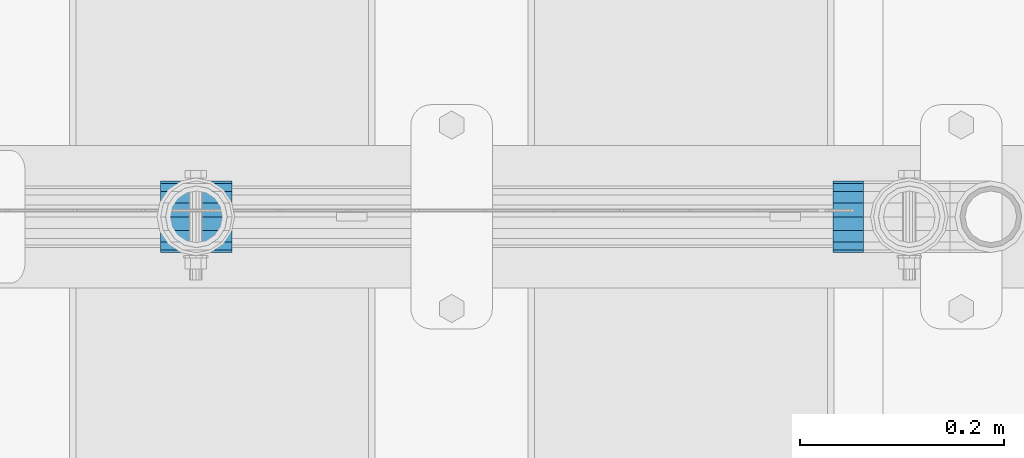
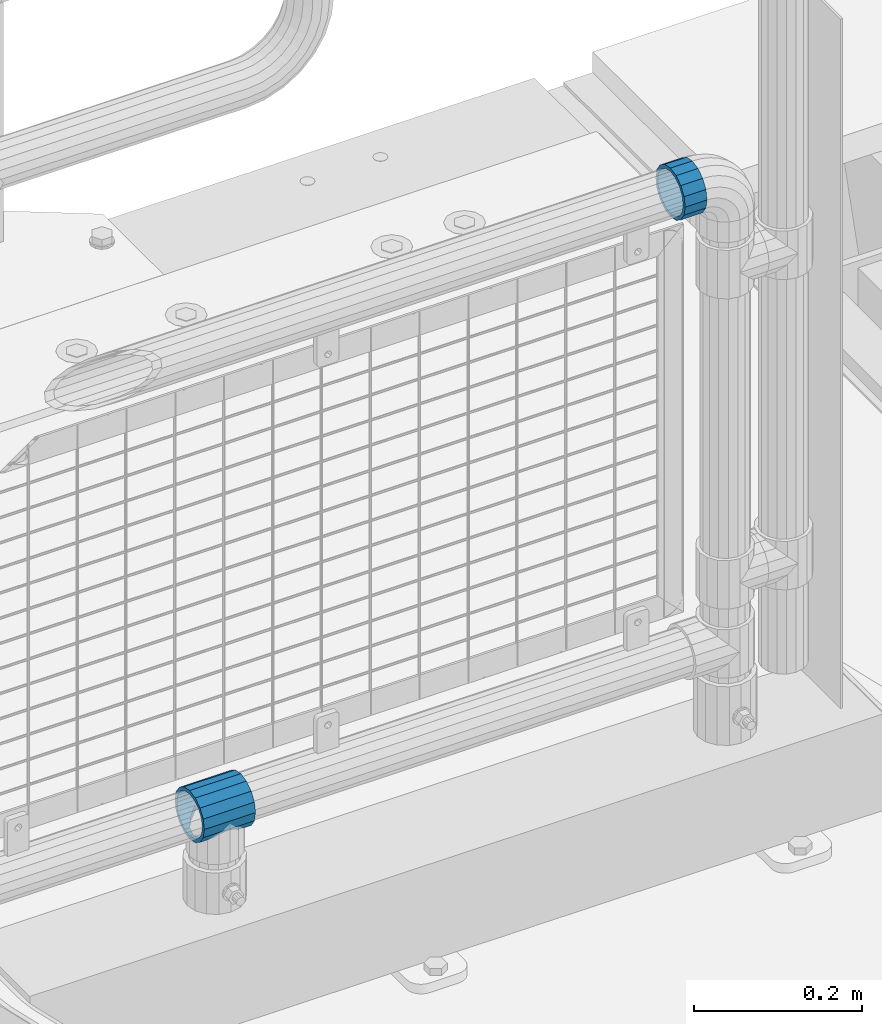
# One storey, part 189 of 270: 2 beams.
"""IFC2X3 building model written with IfcOpenShell, lengths in millimetres."""

from ifc_helpers import new_model, si_unit, frame, origin_with_axes, place, context, subcontext, project, spatial, faceted_brep, material, type_object, element, save


model = new_model("IFC2X3")

# Units and contexts
model_context = context("Model", 3, precision=1e-05, world=origin_with_axes())
body_context = subcontext(model_context, "Body", "Model", "MODEL_VIEW")
ifc_project = project(units=[si_unit("LENGTHUNIT", "METRE", prefix="MILLI"), si_unit("AREAUNIT", "SQUARE_METRE"), si_unit("VOLUMEUNIT", "CUBIC_METRE"), si_unit("MASSUNIT", "GRAM", prefix="KILO"), si_unit("TIMEUNIT", "SECOND"), si_unit("PLANEANGLEUNIT", "RADIAN"), si_unit("SOLIDANGLEUNIT", "STERADIAN"), si_unit("THERMODYNAMICTEMPERATUREUNIT", "DEGREE_CELSIUS"), si_unit("LUMINOUSINTENSITYUNIT", "LUMEN")], contexts=[model_context])

# Site, building, storey
site_placement = place(None, origin_with_axes())
site = spatial("IfcSite", under=ifc_project, at=site_placement, CompositionType="ELEMENT")
building_placement = place(site_placement, origin_with_axes())
building = spatial("IfcBuilding", under=site, at=building_placement, Name="Standard", CompositionType="ELEMENT")
storey_placement = place(building_placement, origin_with_axes())
storey = spatial("IfcBuildingStorey", under=building, at=storey_placement, Name="Undefined", CompositionType="ELEMENT", Elevation=0.0)

# Beams
ifc_material = material(Name="Misc_Undefined")
beam_type = type_object("IfcBeamType", PredefinedType="NOTDEFINED")
beam_1_placement = place(storey_placement, frame((19059.46, -16335.5, 298.169999999999), z_axis=(0.0, 0.0, 1.0), x_axis=(1.0, 0.0, 0.0)))
element("IfcBeam", 1, at=beam_1_placement, inside=storey, type_object=beam_type, material=ifc_material, context=body_context, shape_type="Brep", body=[
    faceted_brep([(61.9623795176767, -13.4513226476338, -32.4743655677703), (56.6106908090125, -21.4606908090118, -27.1226768591041), (56.6106908090125, -21.4606908090118, -21.46069080901), (63.1897438117183, -11.6144421722802, -28.0397438117179), (63.1897438117183, -11.6144421722802, -32.8397438117172), (51.5310424080071, -24.8548033587067, -24.8548033587067), (46.7644421722812, -28.0397438117179, -20.0882031229885), (46.7644421722812, -28.0397438117179, -11.614442172282), (35.1500000000008, -30.3500000000004, -16.6306603983721), (35.1500000000015, -30.35, 0.0), (23.5355578277203, -28.0397438117179, -20.0882031229885), (23.5355578277203, -28.0397438117179, -11.614442172282), (13.689309190989, -21.4606908090118, -27.1226768591041), (13.689309190989, -21.4606908090118, -21.46069080901), (18.7689575919954, -24.8548033587067, -24.8548033587067), (7.11025618828319, -11.6144421722802, -32.8397438117172), (7.11025618828319, -11.6144421722802, -28.0397438117179), (8.33762048232484, -13.4513226476338, -32.4743655677703), (4.80000000000075, 0.0, -35.1500000000015), (4.80000000000075, 0.0, -30.3499999999985), (7.11025618828324, 11.6144421722802, -32.8397438117208), (7.11025618828324, 11.6144421722802, -28.0397438117179), (8.33762048232484, 13.4513226476338, -32.4743655677703), (13.689309190989, 21.4606908090118, -27.1226768591005), (13.689309190989, 21.4606908090118, -21.46069080901), (18.7689575919954, 24.8548033587067, -24.8548033587067), (23.5355578277203, 28.0397438117179, -20.0882031229812), (23.5355578277203, 28.0397438117179, -11.614442172282), (35.1500000000008, 30.3500000000004, -16.6306603983612), (35.1500000000015, 30.35, 0.0), (46.7644421722812, 28.0397438117179, -20.0882031229812), (46.7644421722812, 28.0397438117179, -11.614442172282), (56.6106908090125, 21.4606908090118, -27.1226768591005), (56.6106908090125, 21.4606908090118, -21.46069080901), (51.5310424080071, 24.8548033587067, -24.8548033587067), (63.1897438117183, 11.6144421722802, -32.8397438117208), (63.1897438117183, 11.6144421722802, -28.0397438117179), (61.9623795176767, 13.4513226476338, -32.4743655677703), (65.5000000000008, 0.0, -35.1500000000015), (65.5000000000008, 0.0, -30.3499999999985), (0.0, -21.4606908090118, -21.46069080901), (0.0, -28.0397438117179, -11.614442172282), (0.0, -11.6144421722802, -28.0397438117179), (0.0, 0.0, -30.3499999999985), (0.0, 11.6144421722802, -28.0397438117179), (0.0, 21.4606908090118, -21.46069080901), (0.0, 28.0397438117179, -11.614442172282), (0.0, 30.3500000000004, 0.0), (0.0, 32.4743655677721, -13.4513226476338), (0.0, 35.1499999999996, 0.0), (70.2999999999993, 35.1499999999996, 0.0), (70.2999999999993, 32.4743655677721, -13.4513226476338), (0.0, 32.4743655677721, 13.4513226476338), (70.2999999999993, 32.4743655677721, 13.4513226476338), (0.0, 24.8548033587067, 24.8548033587067), (70.2999999999993, 24.8548033587067, 24.8548033587067), (0.0, 13.4513226476338, 32.4743655677703), (70.2999999999993, 13.4513226476338, 32.4743655677703), (0.0, 0.0, 35.1499999999996), (70.2999999999993, 0.0, 35.1500000000015), (0.0, -13.4513226476338, 32.4743655677703), (70.2999999999993, -13.4513226476338, 32.4743655677703), (0.0, -24.8548033587067, 24.8548033587067), (70.2999999999993, -24.8548033587067, 24.8548033587067), (0.0, -32.4743655677721, 13.4513226476338), (70.2999999999993, -32.4743655677721, 13.4513226476338), (0.0, -35.1499999999996, 0.0), (70.2999999999993, -35.1499999999996, 0.0), (0.0, -32.4743655677721, -13.4513226476338), (70.2999999999993, -32.4743655677721, -13.4513226476338), (0.0, 24.8548033587067, -24.8548033587067), (0.0, 13.4513226476338, -32.4743655677703), (0.0, 0.0, -35.1499999999996), (0.0, -13.4513226476338, -32.4743655677703), (0.0, -24.8548033587067, -24.8548033587067), (0.0, 28.0397438117179, 11.614442172282), (0.0, 21.4606908090118, 21.46069080901), (0.0, 11.6144421722802, 28.0397438117179), (0.0, 0.0, 30.3499999999985), (0.0, -11.6144421722802, 28.0397438117179), (0.0, -21.4606908090118, 21.46069080901), (0.0, -28.0397438117179, 11.614442172282), (0.0, -30.3500000000004, 0.0), (70.2999999999993, -30.3500000000004, 0.0), (70.2999999999993, -28.0397438117179, -11.614442172282), (70.2999999999993, -21.4606908090118, -21.46069080901), (70.2999999999993, -11.6144421722802, -28.0397438117179), (70.2999999999993, 0.0, -30.3499999999985), (70.2999999999993, 21.4606908090118, -21.46069080901), (70.2999999999993, 28.0397438117179, -11.614442172282), (70.2999999999993, 11.6144421722802, -28.0397438117179), (70.2999999999993, 30.3500000000004, 0.0), (70.2999999999993, 28.0397438117179, 11.614442172282), (70.2999999999993, 21.4606908090118, 21.46069080901), (70.2999999999993, 11.6144421722802, 28.0397438117179), (70.2999999999993, 0.0, 30.3499999999985), (70.2999999999993, -11.6144421722802, 28.0397438117179), (70.2999999999993, -21.4606908090118, 21.46069080901), (70.2999999999993, -28.0397438117179, 11.614442172282), (70.2999999999993, -24.8548033587067, -24.8548033587067), (70.2999999999993, -13.4513226476338, -32.4743655677703), (70.2999999999993, 0.0, -35.1500000000015), (70.2999999999993, 13.4513226476338, -32.4743655677703), (70.2999999999993, 24.8548033587067, -24.8548033587067)], [[[0, 1, 2, 3, 4]], [[5, 6, 7, 2, 1]], [[8, 9, 7, 6]], [[10, 11, 9, 8]], [[12, 13, 11, 10, 14]], [[15, 16, 13, 12, 17]], [[18, 19, 16, 15]], [[20, 21, 19, 18]], [[22, 23, 24, 21, 20]], [[25, 26, 27, 24, 23]], [[28, 29, 27, 26]], [[30, 31, 29, 28]], [[32, 33, 31, 30, 34]], [[35, 36, 33, 32, 37]], [[38, 39, 36, 35]], [[4, 3, 39, 38]], [[40, 41, 11, 13]], [[42, 40, 13, 16]], [[43, 42, 16, 19]], [[44, 43, 19, 21]], [[45, 44, 21, 24]], [[46, 45, 24, 27]], [[47, 46, 27, 29]], [[48, 49, 50, 51]], [[49, 52, 53, 50]], [[52, 54, 55, 53]], [[54, 56, 57, 55]], [[56, 58, 59, 57]], [[58, 60, 61, 59]], [[60, 62, 63, 61]], [[62, 64, 65, 63]], [[64, 66, 67, 65]], [[66, 68, 69, 67]], [[64, 62, 60, 58, 56, 54, 52, 49, 48, 70, 71, 72, 73, 74, 68, 66], [41, 40, 42, 43, 44, 45, 46, 47, 75, 76, 77, 78, 79, 80, 81, 82]], [[41, 82, 9, 11]], [[83, 84, 7, 9]], [[84, 85, 2, 7]], [[85, 86, 3, 2]], [[86, 87, 39, 3]], [[88, 89, 31, 33]], [[90, 88, 33, 36]], [[87, 90, 36, 39]], [[89, 91, 29, 31]], [[75, 47, 29, 91, 92]], [[76, 75, 92, 93]], [[77, 76, 93, 94]], [[78, 77, 94, 95]], [[79, 78, 95, 96]], [[80, 79, 96, 97]], [[81, 80, 97, 98]], [[9, 82, 81, 98, 83]], [[99, 100, 101, 102, 103, 51, 50, 53, 55, 57, 59, 61, 63, 65, 67, 69], [97, 96, 95, 94, 93, 92, 91, 89, 88, 90, 87, 86, 85, 84, 83, 98]], [[37, 102, 101, 38, 35]], [[34, 103, 102, 37, 32]], [[70, 48, 51, 103, 34, 30, 28, 26, 25]], [[71, 70, 25, 23, 22]], [[72, 71, 22, 20, 18]], [[17, 73, 72, 18, 15]], [[14, 74, 73, 17, 12]], [[8, 6, 5, 99, 69, 68, 74, 14, 10]], [[100, 99, 5, 1, 0]], [[101, 100, 0, 4, 38]]]),
])
beam_2_placement = place(storey_placement, frame((19749.0, -16335.5, 969.85), z_axis=(0.0, 0.0, 1.0), x_axis=(-1.0, 0.0, 0.0)))
element("IfcBeam", 2, at=beam_2_placement, inside=storey, type_object=beam_type, material=ifc_material, context=body_context, shape_type="Brep", body=[
    faceted_brep([(0.0, -30.3500000000004, 0.0), (0.0, -28.0397438117179, 11.614442172282), (30.0, -28.0397438117179, 11.6144421722805), (30.0, -30.3500000000004, 0.0), (0.0, -21.4606908090118, 21.46069080901), (30.0, -21.4606908090118, 21.4606908090117), (0.0, -11.6144421722802, 28.0397438117179), (30.0, -11.6144421722802, 28.0397438117176), (0.0, 0.0, 30.3499999999985), (30.0, 0.0, 30.35), (0.0, 11.6144421722802, 28.0397438117179), (30.0, 11.6144421722802, 28.0397438117176), (0.0, 21.4606908090118, 21.46069080901), (30.0, 21.4606908090118, 21.4606908090117), (0.0, 28.0397438117179, 11.614442172282), (30.0, 28.0397438117179, 11.6144421722805), (0.0, 30.3500000000004, 0.0), (30.0, 30.3500000000004, 0.0), (0.0, 28.0397438117179, -11.614442172282), (30.0, 28.0397438117179, -11.6144421722805), (0.0, 21.4606908090118, -21.46069080901), (30.0, 21.4606908090118, -21.4606908090117), (0.0, 11.6144421722802, -28.0397438117179), (30.0, 11.6144421722802, -28.0397438117176), (0.0, 0.0, -30.3499999999985), (30.0, 0.0, -30.35), (0.0, -11.6144421722802, -28.0397438117179), (30.0, -11.6144421722802, -28.0397438117176), (0.0, -21.4606908090118, -21.46069080901), (30.0, -21.4606908090118, -21.4606908090117), (0.0, -28.0397438117179, -11.614442172282), (30.0, -28.0397438117179, -11.6144421722805), (0.0, -35.1499999999996, 0.0), (0.0, -32.4743655677721, -13.4513226476338), (30.0, -32.4743655677721, -13.4513226476329), (30.0, -35.1499999999996, 0.0), (0.0, -24.8548033587067, -24.8548033587067), (30.0, -24.8548033587067, -24.8548033587072), (0.0, -13.4513226476338, -32.4743655677703), (30.0, -13.4513226476338, -32.4743655677718), (0.0, 0.0, -35.1499999999996), (30.0, 0.0, -35.15), (0.0, 13.4513226476338, -32.4743655677703), (30.0, 13.4513226476338, -32.4743655677718), (0.0, 24.8548033587067, -24.8548033587067), (30.0, 24.8548033587067, -24.8548033587072), (0.0, 32.4743655677721, -13.4513226476338), (30.0, 32.4743655677721, -13.4513226476329), (0.0, 35.1499999999996, 0.0), (30.0, 35.1499999999996, 0.0), (0.0, 32.4743655677721, 13.4513226476338), (30.0, 32.4743655677721, 13.4513226476329), (0.0, 24.8548033587067, 24.8548033587067), (30.0, 24.8548033587067, 24.8548033587072), (0.0, 13.4513226476338, 32.4743655677703), (30.0, 13.4513226476338, 32.4743655677718), (0.0, 0.0, 35.1499999999996), (30.0, 0.0, 35.15), (0.0, -13.4513226476338, 32.4743655677703), (30.0, -13.4513226476338, 32.4743655677718), (0.0, -24.8548033587067, 24.8548033587067), (30.0, -24.8548033587067, 24.8548033587072), (0.0, -32.4743655677721, 13.4513226476338), (30.0, -32.4743655677721, 13.4513226476329)], [[[0, 1, 2, 3]], [[1, 4, 5, 2]], [[4, 6, 7, 5]], [[6, 8, 9, 7]], [[8, 10, 11, 9]], [[10, 12, 13, 11]], [[12, 14, 15, 13]], [[14, 16, 17, 15]], [[16, 18, 19, 17]], [[18, 20, 21, 19]], [[20, 22, 23, 21]], [[22, 24, 25, 23]], [[24, 26, 27, 25]], [[26, 28, 29, 27]], [[28, 30, 31, 29]], [[30, 0, 3, 31]], [[32, 33, 34, 35]], [[33, 36, 37, 34]], [[36, 38, 39, 37]], [[38, 40, 41, 39]], [[40, 42, 43, 41]], [[42, 44, 45, 43]], [[44, 46, 47, 45]], [[46, 48, 49, 47]], [[48, 50, 51, 49]], [[50, 52, 53, 51]], [[52, 54, 55, 53]], [[54, 56, 57, 55]], [[56, 58, 59, 57]], [[58, 60, 61, 59]], [[60, 62, 63, 61]], [[62, 32, 35, 63]], [[37, 39, 41, 43, 45, 47, 49, 51, 53, 55, 57, 59, 61, 63, 35, 34], [5, 7, 9, 11, 13, 15, 17, 19, 21, 23, 25, 27, 29, 31, 3, 2]], [[62, 60, 58, 56, 54, 52, 50, 48, 46, 44, 42, 40, 38, 36, 33, 32], [30, 28, 26, 24, 22, 20, 18, 16, 14, 12, 10, 8, 6, 4, 1, 0]]]),
])

save(model, "model.ifc")
